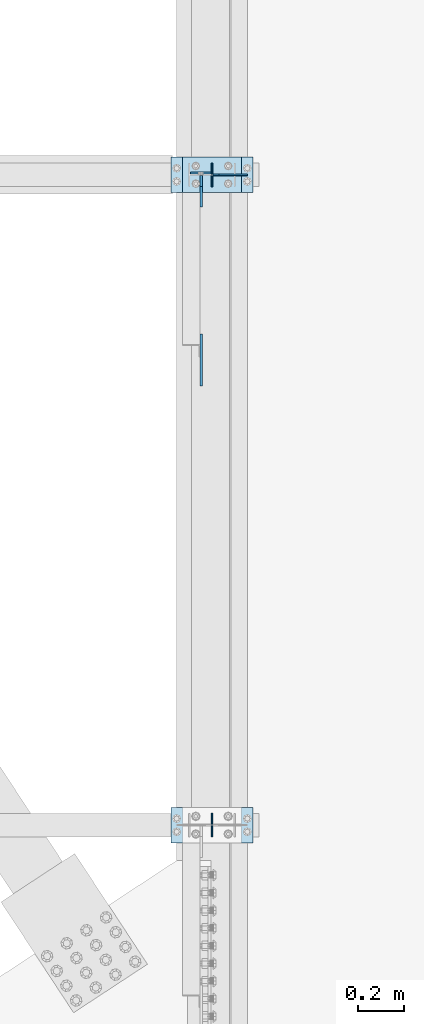
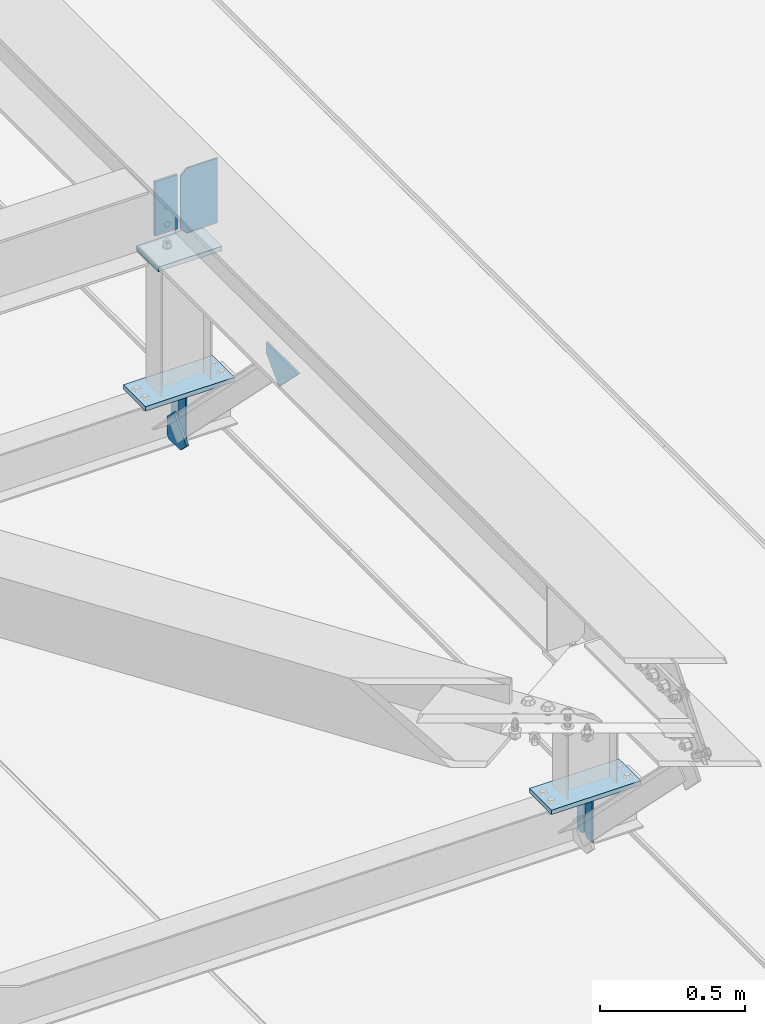
# One storey, part 3357 of 3843: 11 plates, 5 elements without a shape of their own.
"""IFC2X3 building model written with IfcOpenShell, lengths in millimetres."""

from ifc_helpers import new_model, si_unit, frame, origin_with_axes, place, context, subcontext, project, spatial, faceted_brep, material, type_object, element, aggregate, save


model = new_model("IFC2X3")

# Units and contexts
model_context = context("Model", 3, precision=1e-05, world=origin_with_axes())
body_context = subcontext(model_context, "Body", "Model", "MODEL_VIEW")
ifc_project = project(units=[si_unit("LENGTHUNIT", "METRE", prefix="MILLI"), si_unit("AREAUNIT", "SQUARE_METRE"), si_unit("VOLUMEUNIT", "CUBIC_METRE"), si_unit("MASSUNIT", "GRAM", prefix="KILO"), si_unit("TIMEUNIT", "SECOND"), si_unit("PLANEANGLEUNIT", "RADIAN"), si_unit("SOLIDANGLEUNIT", "STERADIAN"), si_unit("THERMODYNAMICTEMPERATUREUNIT", "DEGREE_CELSIUS"), si_unit("LUMINOUSINTENSITYUNIT", "LUMEN")], contexts=[model_context])

# Site, building, storey
site_placement = place(None, origin_with_axes())
site = spatial("IfcSite", under=ifc_project, at=site_placement, CompositionType="ELEMENT")
building_placement = place(site_placement, origin_with_axes())
building = spatial("IfcBuilding", under=site, at=building_placement, Name="Undefined", CompositionType="ELEMENT")
storey_placement = place(building_placement, origin_with_axes())
storey = spatial("IfcBuildingStorey", under=building, at=storey_placement, Name="Undefined", CompositionType="ELEMENT", Elevation=0.0)

# Assembly, plate
assembly_1_placement = place(storey_placement, origin_with_axes())
assembly_1 = element("IfcElementAssembly", 1, at=assembly_1_placement, inside=storey, Name="BEAM", AssemblyPlace="NOTDEFINED", PredefinedType="RIGID_FRAME")
ifc_material = material(Name="STEEL/A572-50")
plate_type_1 = type_object("IfcPlateType", PredefinedType="NOTDEFINED")
plate_1_placement = place(assembly_1_placement, frame((42057.6375, 71458.1375, 42392.3759930237), z_axis=(-1.0, 0.0, 0.0), x_axis=(0.0, 0.0, -1.0)))
plate_1 = element("IfcPlate", 2, at=plate_1_placement, type_object=plate_type_1, material=ifc_material, Name="PLATE", context=body_context, shape_type="Brep", body=[
    faceted_brep([(0.0, -4.76249999999709, 0.0), (0.0, -4.76249999999709, 88.9000015258789), (0.0, 4.76249999999709, 88.9000015258789), (0.0, 4.76249999999709, 0.0), (228.600006102781, -4.7625000004191, 88.9000015257589), (228.600006102781, 4.76249999954598, 88.9000015257443), (228.600006103079, -4.7625000004482, 7.27595761418343e-12), (228.600006103079, 4.76249999954598, -7.27595761418343e-12)], [[[0, 1, 2, 3]], [[1, 4, 5, 2]], [[4, 6, 7, 5]], [[6, 0, 3, 7]], [[5, 7, 3, 2]], [[6, 4, 1, 0]]]),
])

# Assembly, plates
assembly_2_placement = place(storey_placement, origin_with_axes())
assembly_2 = element("IfcElementAssembly", 3, at=assembly_2_placement, inside=storey, Name="BEAM", AssemblyPlace="NOTDEFINED", PredefinedType="RIGID_FRAME")
plate_type_2 = type_object("IfcPlateType", PredefinedType="NOTDEFINED")
plate_2_placement = place(assembly_2_placement, frame((42062.4, 68592.7, 41495.6625), z_axis=(0.0, 0.0, -1.0), x_axis=(0.0, 1.0, 0.0)))
plate_2 = element("IfcPlate", 4, at=plate_2_placement, type_object=plate_type_2, material=ifc_material, Name="PLATE", context=body_context, shape_type="Brep", body=[
    faceted_brep([(0.0, -3.17499999999927, 0.0), (0.0, -3.17500000000291, 187.324999999997), (0.0, 3.17500000000291, 187.324999999997), (0.0, 3.17499999999927, 0.0), (34.9250001907349, -3.17500000000291, 187.324999999997), (34.9250001907349, 3.17500000000291, 187.324999999997), (47.625, -3.17500000000291, 174.625000190732), (47.625, 3.17500000000291, 174.625000190732), (47.625, -3.17499999999927, 12.6999998092651), (47.625, 3.17499999999927, 12.6999998092651), (34.9250001907349, -3.17499999999927, 0.0), (34.9250001907349, 3.17499999999927, 0.0)], [[[0, 1, 2, 3]], [[1, 4, 5, 2]], [[4, 6, 7, 5]], [[6, 8, 9, 7]], [[8, 10, 11, 9]], [[10, 0, 3, 11]], [[5, 7, 9, 11, 3, 2]], [[10, 8, 6, 4, 1, 0]]]),
])
plate_3_placement = place(assembly_2_placement, frame((42062.4, 68694.3, 41495.6625), z_axis=(0.0, 0.0, -1.0), x_axis=(0.0, -1.0, 0.0)))
plate_3 = element("IfcPlate", 5, at=plate_3_placement, type_object=plate_type_2, material=ifc_material, Name="PLATE", context=body_context, shape_type="Brep", body=[
    faceted_brep([(0.0, -3.17499999999927, 0.0), (0.0, -3.17500000000291, 187.324999999997), (0.0, 3.17500000000291, 187.324999999997), (0.0, 3.17499999999927, 0.0), (34.9250001907349, -3.17500000000291, 187.324999999997), (34.9250001907349, 3.17500000000291, 187.324999999997), (47.625, -3.17500000000291, 174.625000190732), (47.625, 3.17500000000291, 174.625000190732), (47.625, -3.17499999999927, 12.6999998092651), (47.625, 3.17499999999927, 12.6999998092651), (34.9250001907349, -3.17499999999927, 0.0), (34.9250001907349, 3.17499999999927, 0.0)], [[[0, 1, 2, 3]], [[1, 4, 5, 2]], [[4, 6, 7, 5]], [[6, 8, 9, 7]], [[8, 10, 11, 9]], [[10, 0, 3, 11]], [[5, 7, 9, 11, 3, 2]], [[10, 8, 6, 4, 1, 0]]]),
])
aggregate(assembly_2, [plate_2, plate_3])

assembly_3_placement = place(storey_placement, origin_with_axes())
assembly_3 = element("IfcElementAssembly", 6, at=assembly_3_placement, inside=storey, Name="BEAM", AssemblyPlace="NOTDEFINED", PredefinedType="RIGID_FRAME")
plate_4_placement = place(assembly_3_placement, frame((42062.4, 71399.4, 41495.6625), z_axis=(0.0, 0.0, -1.0), x_axis=(0.0, 1.0, 0.0)))
plate_4 = element("IfcPlate", 7, at=plate_4_placement, type_object=plate_type_2, material=ifc_material, Name="PLATE", context=body_context, shape_type="Brep", body=[
    faceted_brep([(0.0, -3.17499999999927, 0.0), (0.0, -3.17500000000291, 187.324999999997), (0.0, 3.17500000000291, 187.324999999997), (0.0, 3.17499999999927, 0.0), (34.9250001907349, -3.17500000000291, 187.324999999997), (34.9250001907349, 3.17500000000291, 187.324999999997), (47.625, -3.17500000000291, 174.625000190732), (47.625, 3.17500000000291, 174.625000190732), (47.625, -3.17499999999927, 12.6999998092651), (47.625, 3.17499999999927, 12.6999998092651), (34.9250001907349, -3.17499999999927, 0.0), (34.9250001907349, 3.17499999999927, 0.0)], [[[0, 1, 2, 3]], [[1, 4, 5, 2]], [[4, 6, 7, 5]], [[6, 8, 9, 7]], [[8, 10, 11, 9]], [[10, 0, 3, 11]], [[5, 7, 9, 11, 3, 2]], [[10, 8, 6, 4, 1, 0]]]),
])
plate_5_placement = place(assembly_3_placement, frame((42062.4, 71501.0, 41495.6625), z_axis=(0.0, 0.0, -1.0), x_axis=(0.0, -1.0, 0.0)))
plate_5 = element("IfcPlate", 8, at=plate_5_placement, type_object=plate_type_2, material=ifc_material, Name="PLATE", context=body_context, shape_type="Brep", body=[
    faceted_brep([(0.0, -3.17499999999927, 0.0), (0.0, -3.17500000000291, 187.324999999997), (0.0, 3.17500000000291, 187.324999999997), (0.0, 3.17499999999927, 0.0), (34.9250001907349, -3.17500000000291, 187.324999999997), (34.9250001907349, 3.17500000000291, 187.324999999997), (47.625, -3.17500000000291, 174.625000190732), (47.625, 3.17500000000291, 174.625000190732), (47.625, -3.17499999999927, 12.6999998092651), (47.625, 3.17499999999927, 12.6999998092651), (34.9250001907349, -3.17499999999927, 0.0), (34.9250001907349, 3.17499999999927, 0.0)], [[[0, 1, 2, 3]], [[1, 4, 5, 2]], [[4, 6, 7, 5]], [[6, 8, 9, 7]], [[8, 10, 11, 9]], [[10, 0, 3, 11]], [[5, 7, 9, 11, 3, 2]], [[10, 8, 6, 4, 1, 0]]]),
])

# Assembly, plate
assembly_4_placement = place(storey_placement, origin_with_axes())
assembly_4 = element("IfcElementAssembly", 9, at=assembly_4_placement, inside=storey, Name="POST", AssemblyPlace="NOTDEFINED", PredefinedType="RIGID_FRAME")
plate_type_3 = type_object("IfcPlateType", PredefinedType="NOTDEFINED")
plate_6_placement = place(assembly_4_placement, frame((41935.3999969134, 71526.3948793783, 42083.0375013709), z_axis=(0.0, -0.999999856112298, 0.00053644700005559), x_axis=(1.0, 0.0, 0.0)))
plate_6 = element("IfcPlate", 10, at=plate_6_placement, type_object=plate_type_3, material=ifc_material, Name="PLATE", context=body_context, shape_type="Brep", body=[
    faceted_brep([(0.0, -9.52500000000146, 0.0), (0.0, -9.5249999999287, 152.40000000162), (0.0, 9.52500000002328, 152.40000000162), (0.0, 9.52500000000146, 0.0), (254.0, -9.5249999999287, 152.40000000162), (254.0, 9.52500000002328, 152.40000000162), (253.999999999998, -9.52500000000146, 0.0), (253.999999999998, 9.52500000000146, 0.0)], [[[0, 1, 2, 3]], [[1, 4, 5, 2]], [[4, 6, 7, 5]], [[6, 0, 3, 7]], [[5, 7, 3, 2]], [[6, 4, 1, 0]]]),
])

assembly_5_placement = place(storey_placement, origin_with_axes())
assembly_5 = element("IfcElementAssembly", 11, at=assembly_5_placement, inside=storey, Name="POST", AssemblyPlace="NOTDEFINED", PredefinedType="RIGID_FRAME")
plate_7_placement = place(assembly_5_placement, frame((42240.2, 68567.3, 41513.125), z_axis=(-1.0, 0.0, 0.0), x_axis=(0.0, 1.0, 0.0)))
plate_7 = element("IfcPlate", 12, at=plate_7_placement, type_object=plate_type_3, material=ifc_material, Name="PLATE", context=body_context, shape_type="Brep", body=[
    faceted_brep([(0.0, -9.52500000000146, 0.0), (0.0, -9.52500000000146, 355.599999999999), (0.0, 9.52500000000146, 355.599999999999), (0.0, 9.52500000000146, 0.0), (152.399999999994, -9.52500000000146, 355.599999999999), (152.399999999994, 9.52500000000146, 355.599999999999), (152.400000000001, -9.52500000000146, 0.0), (152.400000000001, 9.52500000000146, 0.0)], [[[0, 1, 2, 3]], [[1, 4, 5, 2]], [[4, 6, 7, 5]], [[6, 0, 3, 7]], [[5, 7, 3, 2]], [[6, 4, 1, 0]]]),
])
aggregate(assembly_5, [plate_7])

# Plate
plate_8_placement = place(assembly_4_placement, frame((42240.2, 71374.0, 41513.125), z_axis=(-1.0, 0.0, 0.0), x_axis=(0.0, 1.0, 0.0)))
plate_8 = element("IfcPlate", 13, at=plate_8_placement, type_object=plate_type_3, material=ifc_material, Name="PLATE", context=body_context, shape_type="Brep", body=[
    faceted_brep([(0.0, -9.52500000000146, 0.0), (0.0, -9.52500000000146, 355.599999999999), (0.0, 9.52500000000146, 355.599999999999), (0.0, 9.52500000000146, 0.0), (152.399999999994, -9.52500000000146, 355.599999999999), (152.399999999994, 9.52500000000146, 355.599999999999), (152.400000000001, -9.52500000000146, 0.0), (152.400000000001, 9.52500000000146, 0.0)], [[[0, 1, 2, 3]], [[1, 4, 5, 2]], [[4, 6, 7, 5]], [[6, 0, 3, 7]], [[5, 7, 3, 2]], [[6, 4, 1, 0]]]),
])

aggregate(assembly_4, [plate_6, plate_8])

plate_type_4 = type_object("IfcPlateType", PredefinedType="NOTDEFINED")
plate_9_placement = place(assembly_1_placement, frame((42016.3625, 70539.348423226, 42121.3555541876), z_axis=(0.0, 0.707106781186548, 0.707106781186548), x_axis=(5.70000238222118e-08, 0.707106781186546, -0.707106781186546)))
plate_9 = element("IfcPlate", 14, at=plate_9_placement, type_object=plate_type_4, material=ifc_material, Name="PLATE", context=body_context, shape_type="Brep", body=[
    faceted_brep([(0.0, -4.76249999999709, 0.0), (157.726597423803, -4.76249999999709, 157.726601438866), (157.726597423803, 4.76249999999709, 157.726601438866), (0.0, 4.76249999999709, 0.0), (188.387110059113, -4.76249999999709, 127.066089584019), (188.387110059113, 4.76249999999709, 127.066089584019), (188.387111679331, -4.76249999999709, 1.09139364212751e-10), (188.387111679331, 4.76249999999709, 1.09139364212751e-10)], [[[0, 1, 2, 3]], [[1, 4, 5, 2]], [[4, 6, 7, 5]], [[6, 0, 3, 7]], [[5, 7, 3, 2]], [[6, 4, 1, 0]]]),
])

plate_type_5 = type_object("IfcPlateType", PredefinedType="NOTDEFINED")
plate_10_placement = place(assembly_3_placement, frame((42016.3625, 71447.0250000139, 41306.750000025), z_axis=(0.0, -1.0, 0.0), x_axis=(0.0, 0.0, 1.0)))
plate_10 = element("IfcPlate", 15, at=plate_10_placement, type_object=plate_type_5, material=ifc_material, Name="PLATE", context=body_context, shape_type="Brep", body=[
    faceted_brep([(0.0, -4.76250000000073, 12.6999998092651), (4.450703272596e-08, -4.76249999999709, 93.0710244828806), (4.450703272596e-08, 4.76249999999709, 93.0710244828806), (0.0, 4.76250000000073, 12.6999998092651), (43.3137807601452, -4.76249999999709, 136.384805065652), (43.3137807601452, 4.76249999999709, 136.384805065652), (133.209805202001, -4.76249999999709, 46.4887805392646), (133.209805202001, 4.76249999999709, 46.4887805392646), (86.7210245267561, -4.76249999999709, 0.0), (86.7210245267561, 4.76249999999709, 0.0), (12.6999998092651, -4.76250000000073, 0.0), (12.6999998092651, 4.76250000000073, 0.0)], [[[0, 1, 2, 3]], [[1, 4, 5, 2]], [[4, 6, 7, 5]], [[6, 8, 9, 7]], [[8, 10, 11, 9]], [[10, 0, 3, 11]], [[5, 7, 9, 11, 3, 2]], [[10, 8, 6, 4, 1, 0]]]),
])

aggregate(assembly_3, [plate_10, plate_4, plate_5])

plate_type_6 = type_object("IfcPlateType", PredefinedType="NOTDEFINED")
plate_11_placement = place(assembly_1_placement, frame((42214.8, 71450.3558445591, 42411.427613171), z_axis=(0.0, -0.00053644700004952, -0.999999856112298), x_axis=(-1.0, 0.0, 0.0)))
plate_11 = element("IfcPlate", 16, at=plate_11_placement, type_object=plate_type_6, material=ifc_material, Name="PLATE", context=body_context, shape_type="Brep", body=[
    faceted_brep([(0.0, -3.17499999999927, 0.0), (0.0, -3.17500000007567, 273.049999997937), (0.0, 3.17499999993743, 273.049999997937), (0.0, 3.17499999999927, 0.0), (122.237500389827, -3.17500000007567, 273.049999997937), (122.237500389827, 3.17499999993743, 273.049999997937), (147.637500008357, -3.17500000006476, 247.650000379464), (147.637500008357, 3.17499999994106, 247.650000379464), (147.637500008357, -3.17500000001382, 25.3999996184648), (147.637500008357, 3.17499999999927, 25.3999996184648), (122.237500389827, -3.17500000000291, 0.0), (122.237500389827, 3.17500000000291, -7.27595761418343e-12)], [[[0, 1, 2, 3]], [[1, 4, 5, 2]], [[4, 6, 7, 5]], [[6, 8, 9, 7]], [[8, 10, 11, 9]], [[10, 0, 3, 11]], [[5, 7, 9, 11, 3, 2]], [[10, 8, 6, 4, 1, 0]]]),
])

aggregate(assembly_1, [plate_1, plate_9, plate_11])

save(model, "model.ifc")
